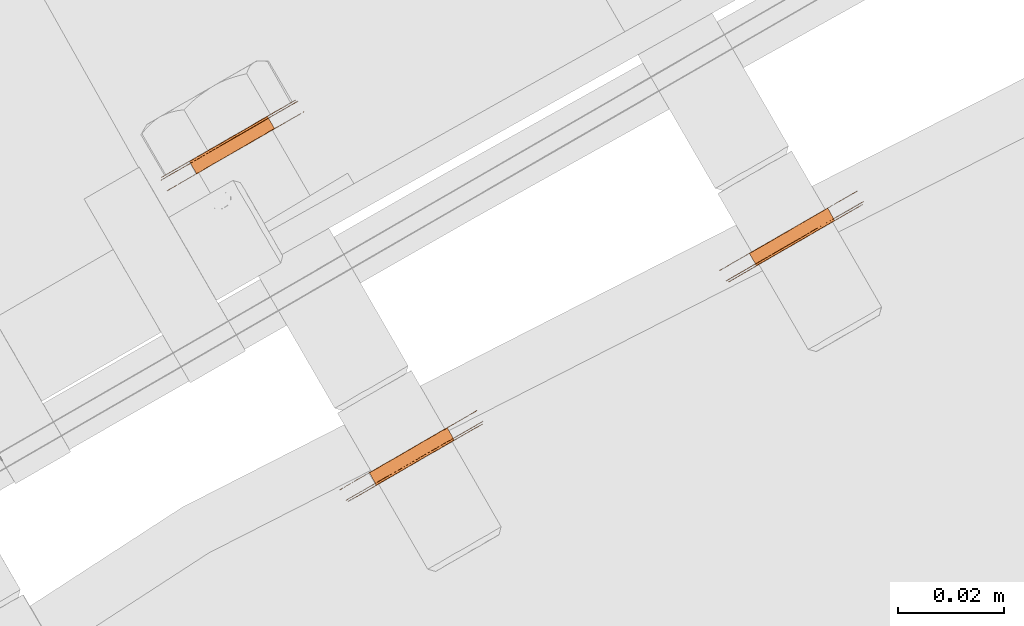
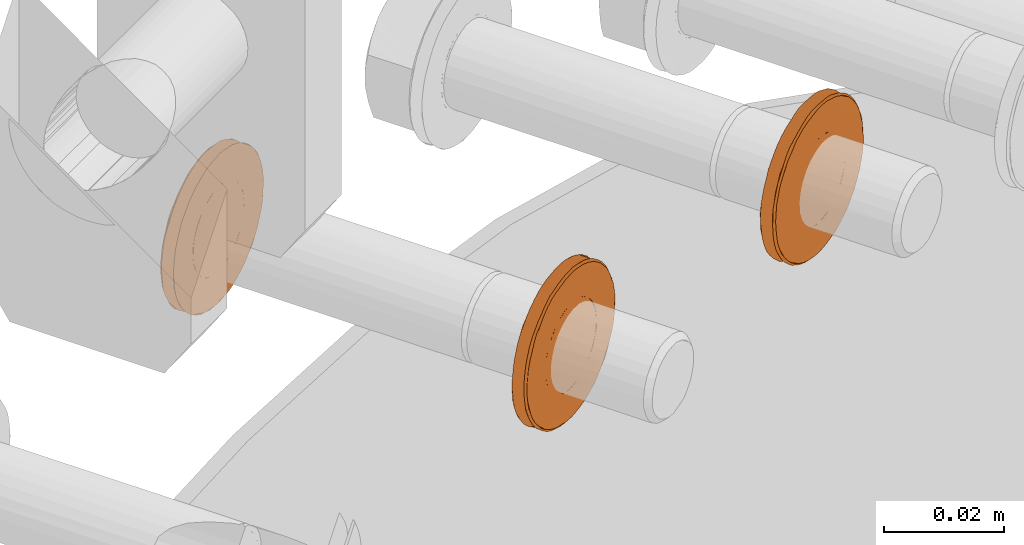
# One storey, part 110 of 126: 3 proxies.
"""IFC2X3 building model written with IfcOpenShell, lengths in millimetres."""

from ifc_helpers import new_model, si_unit, origin, origin_with_axes, place, context, project, spatial, faceted_brep, material, element, save


model = new_model("IFC2X3")

# Units and contexts
context_of_model_1 = context(None, 3, precision=0.1, world=origin())
context_of_model_2 = context(None, 3, precision=0.1, world=origin())
ifc_project = project(units=[si_unit("LENGTHUNIT", "METRE", prefix="MILLI"), si_unit("AREAUNIT", "SQUARE_METRE", prefix="CENTI"), si_unit("VOLUMEUNIT", "CUBIC_METRE", prefix="CENTI"), si_unit("MASSUNIT", "GRAM", prefix="KILO")], contexts=[context_of_model_1, context_of_model_2])

# Site, building, storey
site_placement = place(None, origin_with_axes())
site = spatial("IfcSite", under=ifc_project, at=site_placement, CompositionType="ELEMENT")
building_placement = place(site_placement, origin_with_axes())
building = spatial("IfcBuilding", under=site, at=building_placement, CompositionType="ELEMENT")
storey_placement = place(building_placement, origin_with_axes())
storey = spatial("IfcBuildingStorey", under=building, at=storey_placement, CompositionType="ELEMENT")

# Proxies
ifc_material = material(Name="STAHL")
proxy_1_placement = place(storey_placement, origin_with_axes())
element("IfcBuildingElementProxy", 1, at=proxy_1_placement, inside=storey, material=ifc_material, Name="profile", context=context_of_model_2, shape_type="Brep", body=[
    faceted_brep([(4052.9, 14926.6, 1316.4), (4051.6, 14928.9, 1316.4), (4050.7, 14928.4, 1317.0), (4052.0, 14926.1, 1317.0), (4053.9, 14927.1, 1315.9), (4052.6, 14929.5, 1315.9), (4054.9, 14927.7, 1315.6), (4053.6, 14930.1, 1315.6), (4056.7, 14928.8, 1332.4), (4055.4, 14931.1, 1332.4), (4056.4, 14931.7, 1332.3), (4057.8, 14929.4, 1332.3), (4055.7, 14928.2, 1332.4), (4054.3, 14930.5, 1332.4), (4054.7, 14927.6, 1332.2), (4053.3, 14929.9, 1332.2), (4053.7, 14927.0, 1331.8), (4052.3, 14929.3, 1331.8), (4052.7, 14926.5, 1331.3), (4051.4, 14928.8, 1331.3), (4051.8, 14925.9, 1330.6), (4050.5, 14928.3, 1330.6), (4051.1, 14925.5, 1329.8), (4049.7, 14927.8, 1329.8), (4050.4, 14925.1, 1328.9), (4049.0, 14927.4, 1328.9), (4049.8, 14924.8, 1327.9), (4048.5, 14927.1, 1327.9), (4049.4, 14924.5, 1326.8), (4048.1, 14926.9, 1326.8), (4049.1, 14924.4, 1325.6), (4047.8, 14926.7, 1325.6), (4049.0, 14924.3, 1324.4), (4047.7, 14926.7, 1324.4), (4049.0, 14924.3, 1323.2), (4047.7, 14926.7, 1323.2), (4049.2, 14924.4, 1322.0), (4047.8, 14926.8, 1322.0), (4049.5, 14924.6, 1320.8), (4048.2, 14926.9, 1320.8), (4050.0, 14924.9, 1319.7), (4048.6, 14927.2, 1319.7), (4050.5, 14925.2, 1318.7), (4049.2, 14927.5, 1318.7), (4051.2, 14925.6, 1317.8), (4049.9, 14927.9, 1317.8), (4043.2, 14921.4, 1323.7), (4043.2, 14921.4, 1325.3), (4043.4, 14921.5, 1326.9), (4043.7, 14921.7, 1328.4), (4044.2, 14922.0, 1329.9), (4044.8, 14922.4, 1331.3), (4045.5, 14922.8, 1332.6), (4046.4, 14923.3, 1333.8), (4047.3, 14923.8, 1334.9), (4048.4, 14924.4, 1335.9), (4049.5, 14925.1, 1336.8), (4050.7, 14925.8, 1337.6), (4052.0, 14926.5, 1338.1), (4053.3, 14927.2, 1338.6), (4054.6, 14928.0, 1338.8), (4056.0, 14928.8, 1338.9), (4057.3, 14929.6, 1338.9), (4058.7, 14930.4, 1338.6), (4060.0, 14931.1, 1338.3), (4061.3, 14931.9, 1337.7), (4062.5, 14932.6, 1337.0), (4063.6, 14933.2, 1336.2), (4064.7, 14933.8, 1335.2), (4065.7, 14934.4, 1334.1), (4066.6, 14934.9, 1332.9), (4067.3, 14935.3, 1331.6), (4067.9, 14935.7, 1330.2), (4068.5, 14936.0, 1328.8), (4068.8, 14936.2, 1327.2), (4069.1, 14936.4, 1325.7), (4069.1, 14936.4, 1324.1), (4069.1, 14936.4, 1322.6), (4068.9, 14936.3, 1321.0), (4068.6, 14936.1, 1319.5), (4068.1, 14935.8, 1318.0), (4067.5, 14935.4, 1316.6), (4066.8, 14935.0, 1315.3), (4065.9, 14934.5, 1314.0), (4065.0, 14934.0, 1312.9), (4063.9, 14933.4, 1311.9), (4062.8, 14932.7, 1311.0), (4061.6, 14932.0, 1310.3), (4060.3, 14931.3, 1309.7), (4059.0, 14930.6, 1309.3), (4057.7, 14929.8, 1309.0), (4056.3, 14929.0, 1308.9), (4055.0, 14928.2, 1309.0), (4053.6, 14927.4, 1309.2), (4052.3, 14926.7, 1309.6), (4051.0, 14925.9, 1310.1), (4049.8, 14925.2, 1310.8), (4048.7, 14924.6, 1311.7), (4047.6, 14924.0, 1312.7), (4046.6, 14923.4, 1313.7), (4045.7, 14922.9, 1315.0), (4045.0, 14922.5, 1316.3), (4044.4, 14922.1, 1317.6), (4043.2, 14924.1, 1317.6), (4043.8, 14924.4, 1316.3), (4044.6, 14924.9, 1315.0), (4045.5, 14925.4, 1313.7), (4046.4, 14925.9, 1312.7), (4047.5, 14926.6, 1311.7), (4048.7, 14927.2, 1310.8), (4049.9, 14927.9, 1310.1), (4051.1, 14928.7, 1309.6), (4052.5, 14929.4, 1309.2), (4053.8, 14930.2, 1309.0), (4055.2, 14931.0, 1308.9), (4056.5, 14931.8, 1309.0), (4057.9, 14932.5, 1309.3), (4059.2, 14933.3, 1309.7), (4060.4, 14934.0, 1310.3), (4061.6, 14934.7, 1311.0), (4062.8, 14935.4, 1311.9), (4063.8, 14936.0, 1312.9), (4064.8, 14936.5, 1314.0), (4065.6, 14937.0, 1315.3), (4066.3, 14937.4, 1316.6), (4066.9, 14937.8, 1318.0), (4067.4, 14938.1, 1319.5), (4067.7, 14938.3, 1321.0), (4067.9, 14938.4, 1322.6), (4068.0, 14938.4, 1324.1), (4067.9, 14938.3, 1325.7), (4067.7, 14938.2, 1327.2), (4067.3, 14938.0, 1328.8), (4066.8, 14937.7, 1330.2), (4066.2, 14937.3, 1331.6), (4065.4, 14936.9, 1332.9), (4064.5, 14936.4, 1334.1), (4063.6, 14935.8, 1335.2), (4062.5, 14935.2, 1336.2), (4061.3, 14934.6, 1337.0), (4060.1, 14933.9, 1337.7), (4058.9, 14933.1, 1338.3), (4057.5, 14932.4, 1338.6), (4056.2, 14931.6, 1338.9), (4054.8, 14930.8, 1338.9), (4053.5, 14930.0, 1338.8), (4052.1, 14929.2, 1338.6), (4050.8, 14928.5, 1338.1), (4049.6, 14927.8, 1337.6), (4048.4, 14927.1, 1336.8), (4047.2, 14926.4, 1335.9), (4046.2, 14925.8, 1334.9), (4045.2, 14925.3, 1333.8), (4044.4, 14924.8, 1332.6), (4043.7, 14924.4, 1331.3), (4043.1, 14924.0, 1329.9), (4042.6, 14923.7, 1328.4), (4042.3, 14923.5, 1326.9), (4042.1, 14923.4, 1325.3), (4042.0, 14923.4, 1323.7), (4042.1, 14923.4, 1322.2), (4042.3, 14923.6, 1320.6), (4042.7, 14923.8, 1319.1), (4043.8, 14921.8, 1319.1), (4043.5, 14921.6, 1320.6), (4043.3, 14921.5, 1322.2), (4043.7, 14921.3, 1324.4), (4043.8, 14921.3, 1326.0), (4044.1, 14921.5, 1327.5), (4044.5, 14921.7, 1329.1), (4045.1, 14922.0, 1330.5), (4045.7, 14922.4, 1331.9), (4046.5, 14922.9, 1333.2), (4047.5, 14923.4, 1334.3), (4048.5, 14924.0, 1335.4), (4049.6, 14924.7, 1336.3), (4050.8, 14925.4, 1337.1), (4052.1, 14926.1, 1337.7), (4053.4, 14926.8, 1338.1), (4054.7, 14927.6, 1338.4), (4056.1, 14928.4, 1338.5), (4057.5, 14929.2, 1338.5), (4058.8, 14930.0, 1338.2), (4060.1, 14930.7, 1337.9), (4061.4, 14931.5, 1337.3), (4062.6, 14932.2, 1336.6), (4063.8, 14932.9, 1335.7), (4064.9, 14933.5, 1334.7), (4065.8, 14934.0, 1333.6), (4066.7, 14934.5, 1332.4), (4067.4, 14934.9, 1331.0), (4068.0, 14935.3, 1329.6), (4068.5, 14935.5, 1328.1), (4068.8, 14935.7, 1326.6), (4069.0, 14935.8, 1325.0), (4069.0, 14935.9, 1323.4), (4068.9, 14935.8, 1321.9), (4068.6, 14935.6, 1320.3), (4068.2, 14935.4, 1318.8), (4067.6, 14935.1, 1317.4), (4067.0, 14934.7, 1316.0), (4066.2, 14934.2, 1314.7), (4065.2, 14933.7, 1313.5), (4064.2, 14933.1, 1312.5), (4063.1, 14932.4, 1311.6), (4061.9, 14931.8, 1310.8), (4060.6, 14931.0, 1310.2), (4059.3, 14930.3, 1309.7), (4058.0, 14929.5, 1309.5), (4056.6, 14928.7, 1309.3), (4055.2, 14927.9, 1309.4), (4053.9, 14927.1, 1309.6), (4052.6, 14926.4, 1310.0), (4051.3, 14925.6, 1310.6), (4050.1, 14924.9, 1311.3), (4048.9, 14924.3, 1312.1), (4047.8, 14923.6, 1313.1), (4046.9, 14923.1, 1314.3), (4046.0, 14922.6, 1315.5), (4045.3, 14922.2, 1316.8), (4044.7, 14921.8, 1318.3), (4044.2, 14921.6, 1319.7), (4043.9, 14921.4, 1321.3), (4043.7, 14921.3, 1322.8), (4060.0, 14930.7, 1316.5), (4059.0, 14930.1, 1316.0), (4058.0, 14929.5, 1315.7), (4057.0, 14928.9, 1315.5), (4056.0, 14928.3, 1315.4), (4058.8, 14930.0, 1331.9), (4059.8, 14930.5, 1331.5), (4060.7, 14931.0, 1330.8), (4061.5, 14931.5, 1330.0), (4062.2, 14931.9, 1329.1), (4062.7, 14932.2, 1328.1), (4063.2, 14932.5, 1327.0), (4063.5, 14932.7, 1325.9), (4063.7, 14932.8, 1324.7), (4063.7, 14932.8, 1323.5), (4063.6, 14932.7, 1322.3), (4063.3, 14932.6, 1321.1), (4062.9, 14932.3, 1320.0), (4062.3, 14932.0, 1319.0), (4061.6, 14931.6, 1318.0), (4060.9, 14931.2, 1317.2), (4059.3, 14933.4, 1330.8), (4060.1, 14933.8, 1330.0), (4058.4, 14932.9, 1331.5), (4057.4, 14932.3, 1331.9), (4054.6, 14930.7, 1315.4), (4055.7, 14931.3, 1315.5), (4056.7, 14931.9, 1315.7), (4057.7, 14932.5, 1316.0), (4058.6, 14933.0, 1316.5), (4059.5, 14933.5, 1317.2), (4060.3, 14934.0, 1318.0), (4061.0, 14934.3, 1319.0), (4061.5, 14934.7, 1320.0), (4061.9, 14934.9, 1321.1), (4062.2, 14935.1, 1322.3), (4062.4, 14935.1, 1323.5), (4062.3, 14935.1, 1324.7), (4062.2, 14935.0, 1325.9), (4061.9, 14934.8, 1327.0), (4061.4, 14934.6, 1328.1), (4060.8, 14934.3, 1329.1)], [[[0, 1, 2, 3]], [[4, 5, 1, 0]], [[4, 6, 7, 5]], [[8, 9, 10, 11]], [[12, 13, 9, 8]], [[14, 15, 13, 12]], [[16, 17, 15, 14]], [[18, 19, 17, 16]], [[20, 21, 19, 18]], [[22, 23, 21, 20]], [[24, 25, 23, 22]], [[26, 27, 25, 24]], [[28, 29, 27, 26]], [[30, 31, 29, 28]], [[32, 33, 31, 30]], [[34, 35, 33, 32]], [[36, 37, 35, 34]], [[38, 39, 37, 36]], [[40, 41, 39, 38]], [[42, 43, 41, 40]], [[44, 45, 43, 42]], [[3, 2, 45, 44]], [[46, 47, 48, 49, 50, 51, 52, 53, 54, 55, 56, 57, 58, 59, 60, 61, 62, 63, 64, 65, 66, 67, 68, 69, 70, 71, 72, 73, 74, 75, 76, 77, 78, 79, 80, 81, 82, 83, 84, 85, 86, 87, 88, 89, 90, 91, 92, 93, 94, 95, 96, 97, 98, 99, 100, 101, 102, 103, 104, 105, 106, 107, 108, 109, 110, 111, 112, 113, 114, 115, 116, 117, 118, 119, 120, 121, 122, 123, 124, 125, 126, 127, 128, 129, 130, 131, 132, 133, 134, 135, 136, 137, 138, 139, 140, 141, 142, 143, 144, 145, 146, 147, 148, 149, 150, 151, 152, 153, 154, 155, 156, 157, 158, 159, 160, 161, 162, 103, 102, 163, 164, 165]], [[166, 167, 168, 169, 170, 171, 172, 173, 174, 175, 176, 177, 178, 179, 180, 181, 182, 183, 184, 185, 186, 187, 188, 189, 190, 191, 192, 193, 194, 195, 196, 197, 198, 199, 200, 201, 202, 203, 85, 84, 83, 82, 81, 80, 79, 78, 77, 76, 75, 74, 73, 72, 71, 70, 69, 68, 67, 66, 65, 64, 63, 62, 61, 60, 59, 58, 57, 56, 55, 54, 53, 52, 51, 50, 49, 48, 47, 46, 165, 164, 163, 102, 101, 100, 99, 98, 97, 96, 95, 94, 93, 92, 91, 90, 89, 88, 87, 86, 85, 203, 204, 205, 206, 207, 208, 209, 210, 211, 212, 213, 214, 215, 216, 217, 218, 219, 220, 221, 222, 223]], [[166, 223, 222, 221, 220, 219, 218, 217, 216, 215, 214, 213, 212, 211, 210, 209, 208, 207, 206, 205, 204, 224, 225, 226, 227, 228, 6, 4, 0, 3, 44, 42, 40, 38, 36, 34, 32, 30, 28, 26, 24, 22, 20, 18, 16, 14, 12, 8, 11, 229, 230, 231, 232, 233, 234, 235, 236, 237, 238, 239, 240, 241, 242, 243, 244, 224, 204, 203, 202, 201, 200, 199, 198, 197, 196, 195, 194, 193, 192, 191, 190, 189, 188, 187, 186, 185, 184, 183, 182, 181, 180, 179, 178, 177, 176, 175, 174, 173, 172, 171, 170, 169, 168, 167]], [[231, 245, 246, 232]], [[230, 247, 245, 231]], [[229, 248, 247, 230]], [[228, 249, 7, 6]], [[11, 10, 248, 229]], [[227, 250, 249, 228]], [[226, 251, 250, 227]], [[225, 252, 251, 226]], [[224, 253, 252, 225]], [[244, 254, 253, 224]], [[243, 255, 254, 244]], [[242, 256, 255, 243]], [[241, 257, 256, 242]], [[240, 258, 257, 241]], [[239, 259, 258, 240]], [[238, 260, 259, 239]], [[237, 261, 260, 238]], [[236, 262, 261, 237]], [[235, 263, 262, 236]], [[234, 264, 263, 235]], [[233, 265, 264, 234]], [[232, 246, 265, 233]], [[159, 158, 157, 156, 155, 154, 153, 152, 151, 150, 149, 148, 147, 146, 145, 144, 143, 142, 141, 140, 139, 138, 137, 136, 135, 134, 133, 132, 131, 130, 129, 128, 127, 126, 125, 124, 123, 122, 121, 120, 119, 118, 253, 254, 255, 256, 257, 258, 259, 260, 261, 262, 263, 264, 265, 246, 245, 247, 248, 10, 9, 13, 15, 17, 19, 21, 23, 25, 27, 29, 31, 33, 35, 37, 39, 41, 43, 45, 2, 1, 5, 7, 249, 250, 251, 252, 253, 118, 117, 116, 115, 114, 113, 112, 111, 110, 109, 108, 107, 106, 105, 104, 103, 162, 161, 160]]]),
])
proxy_2_placement = place(storey_placement, origin_with_axes())
element("IfcBuildingElementProxy", 2, at=proxy_2_placement, inside=storey, material=ifc_material, Name="profile", context=context_of_model_2, shape_type="Brep", body=[
    faceted_brep([(4021.8, 14989.9, 1315.5), (4023.2, 14987.6, 1315.5), (4024.2, 14988.2, 1315.7), (4022.8, 14990.5, 1315.7), (4020.8, 14989.3, 1315.4), (4022.1, 14987.0, 1315.4), (4022.6, 14990.4, 1332.3), (4023.6, 14990.9, 1331.9), (4024.9, 14988.6, 1331.9), (4023.9, 14988.0, 1332.3), (4019.7, 14988.7, 1315.6), (4021.1, 14986.4, 1315.6), (4024.6, 14991.5, 1331.5), (4025.9, 14989.2, 1331.5), (4025.5, 14992.0, 1330.8), (4026.8, 14989.7, 1330.8), (4026.3, 14992.5, 1330.0), (4027.6, 14990.1, 1330.0), (4027.0, 14992.9, 1329.1), (4028.3, 14990.5, 1329.1), (4027.5, 14993.2, 1328.1), (4028.9, 14990.9, 1328.1), (4028.0, 14993.5, 1327.0), (4029.4, 14991.1, 1327.0), (4028.3, 14993.7, 1325.9), (4029.7, 14991.3, 1325.9), (4028.5, 14993.8, 1324.7), (4029.8, 14991.4, 1324.7), (4028.5, 14993.8, 1323.5), (4029.9, 14991.4, 1323.5), (4028.4, 14993.7, 1322.3), (4029.7, 14991.4, 1322.3), (4028.1, 14993.5, 1321.1), (4029.4, 14991.2, 1321.1), (4027.7, 14993.3, 1320.0), (4029.0, 14991.0, 1320.0), (4027.1, 14993.0, 1319.0), (4028.5, 14990.6, 1319.0), (4026.4, 14992.6, 1318.0), (4027.8, 14990.2, 1318.0), (4025.7, 14992.1, 1317.2), (4027.0, 14989.8, 1317.2), (4024.8, 14991.6, 1316.5), (4026.1, 14989.3, 1316.5), (4023.8, 14991.1, 1316.0), (4025.2, 14988.7, 1316.0), (4009.5, 14979.7, 1323.7), (4009.6, 14979.7, 1325.3), (4009.8, 14979.8, 1326.9), (4010.1, 14980.0, 1328.4), (4010.6, 14980.3, 1329.9), (4011.2, 14980.6, 1331.3), (4011.9, 14981.1, 1332.6), (4012.7, 14981.5, 1333.8), (4013.7, 14982.1, 1334.9), (4014.7, 14982.7, 1335.9), (4015.9, 14983.4, 1336.8), (4017.1, 14984.0, 1337.6), (4018.3, 14984.8, 1338.1), (4019.6, 14985.5, 1338.6), (4021.0, 14986.3, 1338.8), (4022.3, 14987.1, 1338.9), (4023.7, 14987.9, 1338.9), (4025.0, 14988.6, 1338.6), (4026.4, 14989.4, 1338.3), (4027.6, 14990.1, 1337.7), (4028.8, 14990.9, 1337.0), (4030.0, 14991.5, 1336.2), (4031.1, 14992.1, 1335.2), (4032.0, 14992.7, 1334.1), (4032.9, 14993.2, 1332.9), (4033.7, 14993.6, 1331.6), (4034.3, 14994.0, 1330.2), (4034.8, 14994.3, 1328.8), (4035.2, 14994.5, 1327.2), (4035.4, 14994.6, 1325.7), (4035.5, 14994.7, 1324.1), (4035.4, 14994.7, 1322.6), (4035.2, 14994.5, 1321.0), (4034.9, 14994.3, 1319.5), (4034.4, 14994.1, 1318.0), (4033.8, 14993.7, 1316.6), (4033.1, 14993.3, 1315.3), (4032.3, 14992.8, 1314.0), (4031.1, 14994.8, 1314.0), (4032.0, 14995.3, 1315.3), (4032.7, 14995.7, 1316.6), (4033.3, 14996.1, 1318.0), (4033.8, 14996.3, 1319.5), (4034.1, 14996.5, 1321.0), (4034.3, 14996.6, 1322.6), (4034.3, 14996.7, 1324.1), (4034.3, 14996.6, 1325.7), (4034.0, 14996.5, 1327.2), (4033.7, 14996.3, 1328.8), (4033.1, 14996.0, 1330.2), (4032.5, 14995.6, 1331.6), (4031.8, 14995.2, 1332.9), (4030.9, 14994.7, 1334.1), (4029.9, 14994.1, 1335.2), (4028.8, 14993.5, 1336.2), (4027.7, 14992.8, 1337.0), (4026.5, 14992.1, 1337.7), (4025.2, 14991.4, 1338.3), (4023.9, 14990.6, 1338.6), (4022.5, 14989.9, 1338.9), (4021.2, 14989.1, 1338.9), (4019.8, 14988.3, 1338.8), (4018.5, 14987.5, 1338.6), (4017.2, 14986.8, 1338.1), (4015.9, 14986.0, 1337.6), (4014.7, 14985.3, 1336.8), (4013.6, 14984.7, 1335.9), (4012.5, 14984.1, 1334.9), (4011.6, 14983.5, 1333.8), (4010.7, 14983.1, 1332.6), (4010.0, 14982.6, 1331.3), (4009.4, 14982.3, 1329.9), (4008.9, 14982.0, 1328.4), (4008.6, 14981.8, 1326.9), (4008.4, 14981.7, 1325.3), (4008.4, 14981.7, 1323.7), (4008.5, 14981.7, 1322.2), (4008.7, 14981.9, 1320.6), (4009.0, 14982.1, 1319.1), (4009.6, 14982.4, 1317.6), (4010.2, 14982.7, 1316.3), (4010.9, 14983.2, 1315.0), (4011.8, 14983.7, 1313.7), (4012.8, 14984.2, 1312.7), (4013.9, 14984.8, 1311.7), (4015.0, 14985.5, 1310.8), (4016.2, 14986.2, 1310.1), (4017.5, 14987.0, 1309.6), (4018.8, 14987.7, 1309.2), (4020.2, 14988.5, 1309.0), (4021.5, 14989.3, 1308.9), (4022.9, 14990.1, 1309.0), (4024.2, 14990.8, 1309.3), (4025.5, 14991.6, 1309.7), (4026.8, 14992.3, 1310.3), (4028.0, 14993.0, 1311.0), (4029.1, 14993.7, 1311.9), (4030.2, 14994.3, 1312.9), (4031.3, 14992.3, 1312.9), (4030.3, 14991.7, 1311.9), (4029.1, 14991.0, 1311.0), (4027.9, 14990.3, 1310.3), (4026.7, 14989.6, 1309.7), (4025.4, 14988.8, 1309.3), (4024.0, 14988.1, 1309.0), (4022.7, 14987.3, 1308.9), (4021.3, 14986.5, 1309.0), (4020.0, 14985.7, 1309.2), (4018.6, 14985.0, 1309.6), (4017.4, 14984.2, 1310.1), (4016.2, 14983.5, 1310.8), (4015.0, 14982.9, 1311.7), (4013.9, 14982.2, 1312.7), (4013.0, 14981.7, 1313.7), (4012.1, 14981.2, 1315.0), (4011.3, 14980.7, 1316.3), (4010.7, 14980.4, 1317.6), (4010.2, 14980.1, 1319.1), (4009.8, 14979.9, 1320.6), (4009.6, 14979.7, 1322.2), (4010.8, 14983.6, 1315.5), (4011.7, 14984.1, 1314.3), (4012.6, 14984.6, 1313.1), (4013.7, 14985.2, 1312.1), (4014.9, 14985.9, 1311.3), (4016.1, 14986.6, 1310.6), (4017.4, 14987.3, 1310.0), (4018.7, 14988.1, 1309.6), (4020.0, 14988.9, 1309.4), (4021.4, 14989.7, 1309.3), (4022.8, 14990.5, 1309.5), (4024.1, 14991.2, 1309.7), (4025.4, 14992.0, 1310.2), (4026.7, 14992.7, 1310.8), (4027.9, 14993.4, 1311.6), (4029.0, 14994.1, 1312.5), (4030.0, 14994.7, 1313.5), (4031.0, 14995.2, 1314.7), (4031.8, 14995.6, 1316.0), (4032.4, 14996.0, 1317.4), (4033.0, 14996.4, 1318.8), (4033.4, 14996.6, 1320.3), (4033.7, 14996.8, 1321.9), (4033.8, 14996.8, 1323.4), (4033.8, 14996.8, 1325.0), (4033.6, 14996.7, 1326.6), (4033.3, 14996.5, 1328.1), (4032.8, 14996.2, 1329.6), (4032.2, 14995.9, 1331.0), (4031.5, 14995.5, 1332.4), (4030.6, 14995.0, 1333.6), (4029.7, 14994.4, 1334.7), (4028.6, 14993.8, 1335.7), (4027.4, 14993.2, 1336.6), (4026.2, 14992.5, 1337.3), (4024.9, 14991.7, 1337.9), (4023.6, 14990.9, 1338.2), (4022.3, 14990.2, 1338.5), (4020.9, 14989.4, 1338.5), (4019.5, 14988.6, 1338.4), (4018.2, 14987.8, 1338.1), (4016.9, 14987.1, 1337.7), (4015.6, 14986.3, 1337.1), (4014.4, 14985.6, 1336.3), (4013.3, 14985.0, 1335.4), (4012.3, 14984.4, 1334.3), (4011.3, 14983.9, 1333.2), (4010.5, 14983.4, 1331.9), (4009.9, 14983.0, 1330.5), (4009.3, 14982.7, 1329.1), (4008.9, 14982.5, 1327.5), (4008.6, 14982.3, 1326.0), (4008.5, 14982.2, 1324.4), (4008.5, 14982.2, 1322.8), (4008.7, 14982.3, 1321.3), (4009.0, 14982.5, 1319.7), (4009.5, 14982.8, 1318.3), (4010.1, 14983.1, 1316.8), (4014.8, 14985.8, 1319.7), (4015.3, 14986.2, 1318.7), (4016.0, 14986.6, 1317.8), (4016.8, 14987.0, 1317.0), (4017.7, 14987.6, 1316.4), (4018.7, 14988.1, 1315.9), (4021.5, 14989.8, 1332.4), (4020.5, 14989.1, 1332.4), (4019.5, 14988.5, 1332.2), (4018.5, 14988.0, 1331.8), (4017.5, 14987.4, 1331.3), (4016.6, 14986.9, 1330.6), (4015.9, 14986.5, 1329.8), (4015.2, 14986.1, 1328.9), (4014.6, 14985.8, 1327.9), (4014.2, 14985.5, 1326.8), (4013.9, 14985.4, 1325.6), (4013.8, 14985.3, 1324.4), (4013.8, 14985.3, 1323.2), (4014.0, 14985.4, 1322.0), (4014.3, 14985.6, 1320.8), (4020.8, 14986.2, 1332.2), (4019.8, 14985.6, 1331.8), (4021.8, 14986.8, 1332.4), (4022.9, 14987.4, 1332.4), (4020.1, 14985.8, 1315.9), (4019.1, 14985.2, 1316.4), (4018.2, 14984.7, 1317.0), (4017.4, 14984.2, 1317.8), (4016.7, 14983.8, 1318.7), (4016.1, 14983.5, 1319.7), (4015.7, 14983.2, 1320.8), (4015.3, 14983.0, 1322.0), (4015.2, 14983.0, 1323.2), (4015.2, 14982.9, 1324.4), (4015.3, 14983.0, 1325.6), (4015.6, 14983.2, 1326.8), (4016.0, 14983.4, 1327.9), (4016.5, 14983.7, 1328.9), (4017.2, 14984.1, 1329.8), (4018.0, 14984.6, 1330.6), (4018.9, 14985.1, 1331.3)], [[[0, 1, 2, 3]], [[4, 5, 1, 0]], [[6, 7, 8, 9]], [[10, 11, 5, 4]], [[7, 12, 13, 8]], [[12, 14, 15, 13]], [[14, 16, 17, 15]], [[16, 18, 19, 17]], [[18, 20, 21, 19]], [[20, 22, 23, 21]], [[22, 24, 25, 23]], [[24, 26, 27, 25]], [[28, 29, 27, 26]], [[30, 31, 29, 28]], [[32, 33, 31, 30]], [[34, 35, 33, 32]], [[36, 37, 35, 34]], [[38, 39, 37, 36]], [[40, 41, 39, 38]], [[42, 43, 41, 40]], [[44, 45, 43, 42]], [[3, 2, 45, 44]], [[46, 47, 48, 49, 50, 51, 52, 53, 54, 55, 56, 57, 58, 59, 60, 61, 62, 63, 64, 65, 66, 67, 68, 69, 70, 71, 72, 73, 74, 75, 76, 77, 78, 79, 80, 81, 82, 83, 84, 85, 86, 87, 88, 89, 90, 91, 92, 93, 94, 95, 96, 97, 98, 99, 100, 101, 102, 103, 104, 105, 106, 107, 108, 109, 110, 111, 112, 113, 114, 115, 116, 117, 118, 119, 120, 121, 122, 123, 124, 125, 126, 127, 128, 129, 130, 131, 132, 133, 134, 135, 136, 137, 138, 139, 140, 141, 142, 143, 84, 83, 144, 145, 146, 147, 148, 149, 150, 151, 152, 153, 154, 155, 156, 157, 158, 159, 160, 161, 162, 163, 164, 165]], [[121, 120, 119, 118, 117, 116, 115, 114, 113, 112, 111, 110, 109, 108, 107, 106, 105, 104, 103, 102, 101, 100, 99, 98, 97, 96, 95, 94, 93, 92, 91, 90, 89, 88, 87, 86, 85, 84, 143, 142, 141, 140, 139, 138, 137, 136, 135, 134, 133, 132, 131, 130, 129, 128, 127, 166, 167, 168, 169, 170, 171, 172, 173, 174, 175, 176, 177, 178, 179, 180, 181, 182, 183, 184, 185, 186, 187, 188, 189, 190, 191, 192, 193, 194, 195, 196, 197, 198, 199, 200, 201, 202, 203, 204, 205, 206, 207, 208, 209, 210, 211, 212, 213, 214, 215, 216, 217, 218, 219, 220, 221, 222, 223, 166, 127, 126, 125, 124, 123, 122]], [[218, 217, 216, 215, 214, 213, 212, 211, 210, 209, 208, 207, 206, 205, 204, 203, 202, 201, 200, 199, 198, 197, 196, 195, 194, 193, 192, 191, 190, 189, 188, 187, 186, 185, 184, 183, 182, 181, 180, 179, 178, 177, 176, 175, 174, 173, 172, 171, 170, 169, 168, 167, 166, 223, 222, 224, 225, 226, 227, 228, 229, 10, 4, 0, 3, 44, 42, 40, 38, 36, 34, 32, 30, 28, 26, 24, 22, 20, 18, 16, 14, 12, 7, 6, 230, 231, 232, 233, 234, 235, 236, 237, 238, 239, 240, 241, 242, 243, 244, 224, 222, 221, 220, 219]], [[232, 245, 246, 233]], [[231, 247, 245, 232]], [[230, 248, 247, 231]], [[229, 249, 11, 10]], [[6, 9, 248, 230]], [[228, 250, 249, 229]], [[227, 251, 250, 228]], [[226, 252, 251, 227]], [[225, 253, 252, 226]], [[224, 254, 253, 225]], [[244, 255, 254, 224]], [[243, 256, 255, 244]], [[242, 257, 256, 243]], [[241, 258, 257, 242]], [[240, 259, 258, 241]], [[239, 260, 259, 240]], [[238, 261, 260, 239]], [[237, 262, 261, 238]], [[236, 263, 262, 237]], [[235, 264, 263, 236]], [[234, 265, 264, 235]], [[233, 246, 265, 234]], [[46, 165, 164, 163, 162, 161, 160, 159, 253, 254, 255, 256, 257, 258, 259, 260, 261, 262, 263, 264, 265, 246, 245, 247, 248, 9, 8, 13, 15, 17, 19, 21, 23, 25, 27, 29, 31, 33, 35, 37, 39, 41, 43, 45, 2, 1, 5, 11, 249, 250, 251, 252, 253, 159, 158, 157, 156, 155, 154, 153, 152, 151, 150, 149, 148, 147, 146, 145, 144, 83, 82, 81, 80, 79, 78, 77, 76, 75, 74, 73, 72, 71, 70, 69, 68, 67, 66, 65, 64, 63, 62, 61, 60, 59, 58, 57, 56, 55, 54, 53, 52, 51, 50, 49, 48, 47]]]),
])
proxy_3_placement = place(storey_placement, origin_with_axes())
element("IfcBuildingElementProxy", 3, at=proxy_3_placement, inside=storey, material=ifc_material, Name="profile", context=context_of_model_2, shape_type="Brep", body=[
    faceted_brep([(4122.6, 14966.8, 1301.7), (4121.2, 14969.1, 1301.7), (4120.6, 14968.7, 1302.6), (4121.9, 14966.4, 1302.6), (4123.3, 14967.2, 1300.9), (4122.0, 14969.6, 1300.9), (4124.2, 14967.7, 1300.2), (4122.8, 14970.1, 1300.2), (4125.1, 14968.3, 1299.6), (4123.8, 14970.6, 1299.6), (4129.8, 14970.9, 1315.7), (4128.4, 14973.3, 1315.7), (4129.4, 14973.9, 1315.3), (4130.8, 14971.5, 1315.3), (4128.7, 14970.3, 1315.9), (4127.4, 14972.7, 1315.9), (4127.7, 14969.7, 1316.0), (4126.3, 14972.1, 1316.0), (4126.6, 14969.1, 1315.8), (4125.3, 14971.5, 1315.8), (4125.6, 14968.6, 1315.5), (4124.3, 14970.9, 1315.5), (4124.7, 14968.0, 1315.1), (4123.3, 14970.3, 1315.1), (4123.8, 14967.5, 1314.5), (4122.4, 14969.8, 1314.5), (4122.9, 14967.0, 1313.7), (4121.6, 14969.3, 1313.7), (4122.2, 14966.6, 1312.8), (4120.9, 14968.9, 1312.8), (4121.6, 14966.2, 1311.8), (4120.3, 14968.6, 1311.8), (4121.1, 14966.0, 1310.7), (4119.8, 14968.3, 1310.7), (4120.8, 14965.8, 1309.6), (4119.5, 14968.1, 1309.6), (4120.6, 14965.7, 1308.4), (4119.3, 14968.0, 1308.4), (4120.6, 14965.6, 1307.2), (4119.2, 14968.0, 1307.2), (4120.7, 14965.7, 1306.0), (4119.4, 14968.0, 1306.0), (4121.0, 14965.9, 1304.8), (4119.6, 14968.2, 1304.8), (4121.4, 14966.1, 1303.7), (4120.0, 14968.4, 1303.7), (4114.8, 14962.7, 1307.1), (4114.8, 14962.8, 1308.7), (4115.0, 14962.9, 1310.2), (4115.3, 14963.0, 1311.7), (4115.7, 14963.3, 1313.2), (4116.3, 14963.6, 1314.6), (4117.0, 14964.1, 1316.0), (4117.9, 14964.5, 1317.2), (4118.8, 14965.1, 1318.4), (4119.8, 14965.7, 1319.4), (4121.0, 14966.3, 1320.3), (4122.2, 14967.0, 1321.0), (4123.4, 14967.7, 1321.6), (4124.7, 14968.5, 1322.1), (4126.1, 14969.3, 1322.4), (4127.4, 14970.0, 1322.5), (4128.8, 14970.8, 1322.4), (4130.1, 14971.6, 1322.2), (4131.4, 14972.4, 1321.9), (4132.7, 14973.1, 1321.3), (4133.9, 14973.8, 1320.7), (4135.1, 14974.5, 1319.8), (4136.2, 14975.1, 1318.9), (4137.2, 14975.7, 1317.8), (4138.1, 14976.2, 1316.6), (4138.8, 14976.6, 1315.3), (4139.5, 14977.0, 1313.9), (4140.0, 14977.3, 1312.5), (4140.4, 14977.5, 1311.0), (4140.6, 14977.7, 1309.4), (4140.7, 14977.7, 1307.9), (4140.7, 14977.7, 1306.3), (4140.5, 14977.6, 1304.8), (4140.2, 14977.4, 1303.2), (4139.8, 14977.2, 1301.7), (4139.2, 14976.8, 1300.3), (4138.5, 14976.4, 1299.0), (4137.6, 14975.9, 1297.7), (4136.7, 14975.4, 1296.6), (4135.7, 14974.8, 1295.6), (4134.5, 14974.2, 1294.7), (4133.3, 14973.5, 1293.9), (4132.1, 14972.7, 1293.3), (4130.8, 14972.0, 1292.9), (4129.4, 14971.2, 1292.6), (4128.1, 14970.4, 1292.5), (4126.7, 14969.7, 1292.5), (4125.4, 14968.9, 1292.7), (4124.1, 14968.1, 1293.1), (4122.8, 14967.4, 1293.6), (4121.6, 14966.7, 1294.3), (4120.4, 14966.0, 1295.1), (4119.3, 14965.4, 1296.1), (4118.3, 14964.8, 1297.2), (4117.4, 14964.3, 1298.4), (4116.7, 14963.8, 1299.6), (4116.0, 14963.5, 1301.0), (4115.5, 14963.2, 1302.5), (4115.1, 14962.9, 1304.0), (4114.9, 14962.8, 1305.5), (4113.6, 14964.7, 1307.1), (4113.7, 14964.8, 1305.5), (4114.0, 14964.9, 1304.0), (4114.4, 14965.2, 1302.5), (4114.9, 14965.5, 1301.0), (4115.5, 14965.8, 1299.6), (4116.3, 14966.3, 1298.4), (4117.2, 14966.8, 1297.2), (4118.2, 14967.4, 1296.1), (4119.2, 14968.0, 1295.1), (4120.4, 14968.7, 1294.3), (4121.6, 14969.4, 1293.6), (4122.9, 14970.1, 1293.1), (4124.2, 14970.9, 1292.7), (4125.6, 14971.6, 1292.5), (4126.9, 14972.4, 1292.5), (4128.3, 14973.2, 1292.6), (4129.6, 14974.0, 1292.9), (4130.9, 14974.7, 1293.3), (4132.2, 14975.5, 1293.9), (4133.4, 14976.2, 1294.7), (4134.5, 14976.8, 1295.6), (4135.5, 14977.4, 1296.6), (4136.5, 14977.9, 1297.7), (4137.3, 14978.4, 1299.0), (4138.0, 14978.8, 1300.3), (4138.6, 14979.2, 1301.7), (4139.1, 14979.4, 1303.2), (4139.4, 14979.6, 1304.8), (4139.5, 14979.7, 1306.3), (4139.6, 14979.7, 1307.9), (4139.5, 14979.7, 1309.4), (4139.2, 14979.5, 1311.0), (4138.8, 14979.3, 1312.5), (4138.3, 14979.0, 1313.9), (4137.7, 14978.6, 1315.3), (4136.9, 14978.2, 1316.6), (4136.0, 14977.7, 1317.8), (4135.0, 14977.1, 1318.9), (4134.0, 14976.5, 1319.8), (4132.8, 14975.8, 1320.7), (4131.6, 14975.1, 1321.3), (4130.3, 14974.4, 1321.9), (4129.0, 14973.6, 1322.2), (4127.6, 14972.8, 1322.4), (4126.3, 14972.0, 1322.5), (4124.9, 14971.3, 1322.4), (4123.6, 14970.5, 1322.1), (4122.3, 14969.7, 1321.6), (4121.0, 14969.0, 1321.0), (4119.8, 14968.3, 1320.3), (4118.7, 14967.7, 1319.4), (4117.7, 14967.1, 1318.4), (4116.7, 14966.5, 1317.2), (4115.9, 14966.1, 1316.0), (4115.2, 14965.6, 1314.6), (4114.6, 14965.3, 1313.2), (4114.1, 14965.0, 1311.7), (4113.8, 14964.9, 1310.2), (4113.6, 14964.8, 1308.7), (4115.3, 14962.6, 1307.7), (4115.4, 14962.6, 1309.3), (4115.6, 14962.8, 1310.8), (4116.0, 14963.0, 1312.3), (4116.5, 14963.3, 1313.8), (4117.2, 14963.7, 1315.2), (4118.0, 14964.1, 1316.5), (4118.9, 14964.7, 1317.7), (4119.9, 14965.2, 1318.7), (4121.0, 14965.9, 1319.7), (4122.2, 14966.6, 1320.5), (4123.4, 14967.3, 1321.1), (4124.7, 14968.0, 1321.6), (4126.1, 14968.8, 1321.9), (4127.4, 14969.6, 1322.1), (4128.8, 14970.4, 1322.1), (4130.2, 14971.2, 1321.9), (4131.5, 14971.9, 1321.5), (4132.8, 14972.7, 1321.0), (4134.0, 14973.4, 1320.3), (4135.2, 14974.1, 1319.5), (4136.3, 14974.7, 1318.5), (4137.2, 14975.3, 1317.4), (4138.1, 14975.8, 1316.2), (4138.9, 14976.2, 1314.8), (4139.5, 14976.6, 1313.4), (4140.0, 14976.8, 1312.0), (4140.3, 14977.0, 1310.4), (4140.5, 14977.2, 1308.9), (4140.6, 14977.2, 1307.3), (4140.5, 14977.1, 1305.7), (4140.3, 14977.0, 1304.2), (4139.9, 14976.8, 1302.6), (4139.4, 14976.5, 1301.2), (4138.7, 14976.1, 1299.8), (4137.9, 14975.6, 1298.5), (4137.0, 14975.1, 1297.3), (4136.0, 14974.5, 1296.2), (4134.9, 14973.9, 1295.3), (4133.7, 14973.2, 1294.5), (4132.5, 14972.5, 1293.8), (4131.2, 14971.8, 1293.4), (4129.8, 14971.0, 1293.0), (4128.5, 14970.2, 1292.9), (4127.1, 14969.4, 1292.9), (4125.7, 14968.6, 1293.1), (4124.4, 14967.8, 1293.5), (4123.1, 14967.1, 1294.0), (4121.9, 14966.4, 1294.7), (4120.7, 14965.7, 1295.5), (4119.6, 14965.1, 1296.5), (4118.7, 14964.5, 1297.6), (4117.8, 14964.0, 1298.8), (4117.0, 14963.6, 1300.1), (4116.4, 14963.2, 1301.5), (4115.9, 14962.9, 1303.0), (4115.6, 14962.7, 1304.5), (4115.4, 14962.6, 1306.1), (4130.3, 14971.2, 1299.4), (4129.3, 14970.6, 1299.1), (4128.2, 14970.0, 1299.0), (4127.2, 14969.4, 1299.0), (4126.1, 14968.8, 1299.2), (4131.7, 14972.1, 1314.8), (4132.6, 14972.6, 1314.1), (4133.3, 14973.0, 1313.3), (4134.0, 14973.4, 1312.3), (4134.5, 14973.7, 1311.3), (4134.9, 14973.9, 1310.2), (4135.2, 14974.1, 1309.0), (4135.3, 14974.1, 1307.8), (4135.3, 14974.1, 1306.6), (4135.1, 14974.0, 1305.4), (4134.8, 14973.8, 1304.2), (4134.3, 14973.5, 1303.1), (4133.7, 14973.2, 1302.2), (4133.0, 14972.8, 1301.3), (4132.1, 14972.3, 1300.5), (4131.2, 14971.8, 1299.9), (4130.4, 14974.4, 1314.8), (4124.8, 14971.2, 1299.2), (4125.8, 14971.8, 1299.0), (4126.9, 14972.4, 1299.0), (4127.9, 14973.0, 1299.1), (4128.9, 14973.6, 1299.4), (4129.9, 14974.1, 1299.9), (4130.8, 14974.7, 1300.5), (4131.6, 14975.1, 1301.3), (4132.3, 14975.5, 1302.2), (4132.9, 14975.9, 1303.1), (4133.4, 14976.2, 1304.2), (4133.7, 14976.3, 1305.4), (4133.9, 14976.5, 1306.6), (4134.0, 14976.5, 1307.8), (4133.8, 14976.4, 1309.0), (4133.6, 14976.3, 1310.2), (4133.2, 14976.0, 1311.3), (4132.6, 14975.7, 1312.3), (4132.0, 14975.3, 1313.3), (4131.2, 14974.9, 1314.1)], [[[0, 1, 2, 3]], [[4, 5, 1, 0]], [[6, 7, 5, 4]], [[6, 8, 9, 7]], [[10, 11, 12, 13]], [[14, 15, 11, 10]], [[16, 17, 15, 14]], [[18, 19, 17, 16]], [[20, 21, 19, 18]], [[22, 23, 21, 20]], [[24, 25, 23, 22]], [[26, 27, 25, 24]], [[28, 29, 27, 26]], [[30, 31, 29, 28]], [[32, 33, 31, 30]], [[34, 35, 33, 32]], [[36, 37, 35, 34]], [[38, 39, 37, 36]], [[40, 41, 39, 38]], [[42, 43, 41, 40]], [[44, 45, 43, 42]], [[3, 2, 45, 44]], [[46, 47, 48, 49, 50, 51, 52, 53, 54, 55, 56, 57, 58, 59, 60, 61, 62, 63, 64, 65, 66, 67, 68, 69, 70, 71, 72, 73, 74, 75, 76, 77, 78, 79, 80, 81, 82, 83, 84, 85, 86, 87, 88, 89, 90, 91, 92, 93, 94, 95, 96, 97, 98, 99, 100, 101, 102, 103, 104, 105, 106, 107, 108, 109, 110, 111, 112, 113, 114, 115, 116, 117, 118, 119, 120, 121, 122, 123, 124, 125, 126, 127, 128, 129, 130, 131, 132, 133, 134, 135, 136, 137, 138, 139, 140, 141, 142, 143, 144, 145, 146, 147, 148, 149, 150, 151, 152, 153, 154, 155, 156, 157, 158, 159, 160, 161, 162, 163, 164, 165, 106, 105]], [[166, 167, 168, 169, 170, 171, 172, 173, 174, 175, 176, 177, 178, 179, 180, 181, 182, 183, 184, 185, 186, 187, 188, 189, 190, 191, 192, 193, 194, 195, 196, 197, 198, 199, 200, 201, 202, 203, 204, 205, 87, 86, 85, 84, 83, 82, 81, 80, 79, 78, 77, 76, 75, 74, 73, 72, 71, 70, 69, 68, 67, 66, 65, 64, 63, 62, 61, 60, 59, 58, 57, 56, 55, 54, 53, 52, 51, 50, 49, 48, 47, 46, 105, 104, 103, 102, 101, 100, 99, 98, 97, 96, 95, 94, 93, 92, 91, 90, 89, 88, 87, 205, 206, 207, 208, 209, 210, 211, 212, 213, 214, 215, 216, 217, 218, 219, 220, 221, 222, 223]], [[166, 223, 222, 221, 220, 219, 218, 217, 216, 215, 214, 213, 212, 211, 210, 209, 208, 207, 206, 224, 225, 226, 227, 228, 8, 6, 4, 0, 3, 44, 42, 40, 38, 36, 34, 32, 30, 28, 26, 24, 22, 20, 18, 16, 14, 10, 13, 229, 230, 231, 232, 233, 234, 235, 236, 237, 238, 239, 240, 241, 242, 243, 244, 224, 206, 205, 204, 203, 202, 201, 200, 199, 198, 197, 196, 195, 194, 193, 192, 191, 190, 189, 188, 187, 186, 185, 184, 183, 182, 181, 180, 179, 178, 177, 176, 175, 174, 173, 172, 171, 170, 169, 168, 167]], [[229, 13, 12, 245]], [[228, 246, 9, 8]], [[228, 227, 247, 246]], [[227, 226, 248, 247]], [[226, 225, 249, 248]], [[225, 224, 250, 249]], [[224, 244, 251, 250]], [[244, 243, 252, 251]], [[243, 242, 253, 252]], [[242, 241, 254, 253]], [[241, 240, 255, 254]], [[240, 239, 256, 255]], [[239, 238, 257, 256]], [[238, 237, 258, 257]], [[237, 236, 259, 258]], [[236, 235, 260, 259]], [[235, 234, 261, 260]], [[234, 233, 262, 261]], [[233, 232, 263, 262]], [[232, 231, 264, 263]], [[231, 230, 265, 264]], [[230, 229, 245, 265]], [[106, 165, 164, 163, 162, 161, 160, 159, 158, 157, 156, 155, 154, 153, 152, 151, 150, 149, 148, 147, 146, 145, 144, 143, 142, 141, 140, 139, 138, 137, 136, 135, 134, 133, 132, 131, 130, 129, 128, 127, 126, 125, 124, 251, 252, 253, 254, 255, 256, 257, 258, 259, 260, 261, 262, 263, 264, 265, 245, 12, 11, 15, 17, 19, 21, 23, 25, 27, 29, 31, 33, 35, 37, 39, 41, 43, 45, 2, 1, 5, 7, 9, 246, 247, 248, 249, 250, 251, 124, 123, 122, 121, 120, 119, 118, 117, 116, 115, 114, 113, 112, 111, 110, 109, 108, 107]]]),
])

save(model, "model.ifc")
